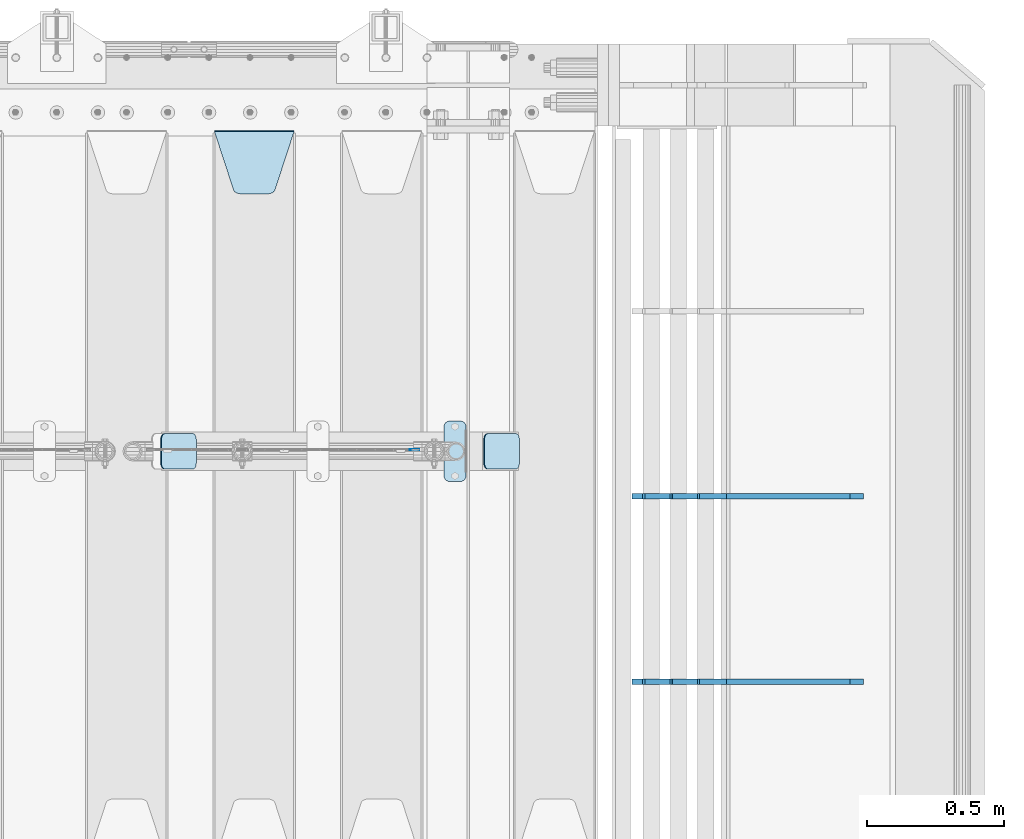
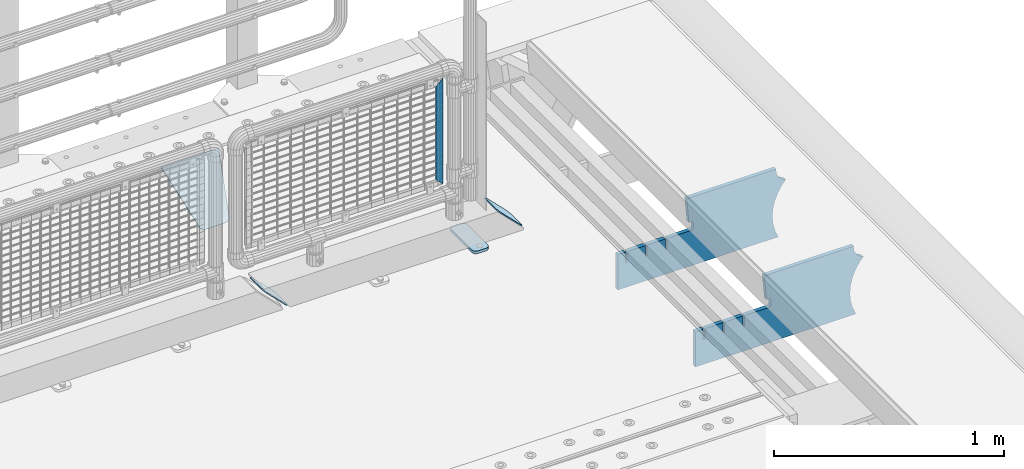
# One storey, part 192 of 208: 7 plates.
"""IFC2X3 building model written with IfcOpenShell, lengths in millimetres."""

import ifcopenshell
import ifcopenshell.guid

model = None  # the IFC model being written
_history = None  # IfcOwnerHistory: only IFC2X3 demands one
_inside = {}  # id of a spatial element -> (the spatial element, [elements in it])
_under = {}  # id of a project, library or spatial element -> (it, [spatial elements below it])
_declared = {}  # id of a project -> (the project, [libraries it declares])
_typed = {}  # id of a type object -> (the type object, [elements of that type])
_made_of = {}  # id of a material, layer set ... -> (it, [elements and type objects made of it])


def new_model(schema):
    """Start an empty IFC model of exactly this schema.

    Asked for "IFC4X3", IfcOpenShell would pick the latest addendum, in which some entities
    have other attributes; the version numbers below select the first issue.
    IFC2X3 requires an IfcOwnerHistory on every rooted entity: one is made here for all.
    """
    global model, _history
    if schema == "IFC4X3":
        model = ifcopenshell.file(schema_version=(4, 3, 0, 0))
    else:
        model = ifcopenshell.file(schema=schema)
    _inside.clear()
    _under.clear()
    _declared.clear()
    _typed.clear()
    _made_of.clear()
    _history = None
    if model.schema == "IFC2X3":
        org = make("IfcOrganization", Name="unknown")
        user = make(
            "IfcPersonAndOrganization",
            ThePerson=make("IfcPerson", FamilyName="unknown"),
            TheOrganization=org,
        )
        app = make(
            "IfcApplication",
            ApplicationDeveloper=org,
            Version="unknown",
            ApplicationFullName="unknown",
            ApplicationIdentifier="unknown",
        )
        _history = make(
            "IfcOwnerHistory",
            OwningUser=user,
            OwningApplication=app,
            ChangeAction="ADDED",
            CreationDate=0,
        )
    return model


def make(cls, **values):
    """One entity of the class cls with the attributes given. An attribute that is None is left unset."""
    return model.create_entity(
        cls, **{name: value for name, value in values.items() if value is not None}
    )


def rooted(cls, **values):
    """An entity with a GlobalId (a new one), such as an element, a storey or a relation."""
    return make(cls, GlobalId=ifcopenshell.guid.new(), OwnerHistory=_history, **values)


def si_unit(unit_type, name, prefix=None):
    """IfcSIUnit, for example si_unit("LENGTHUNIT", "METRE", prefix="MILLI")."""
    return make("IfcSIUnit", UnitType=unit_type, Prefix=prefix, Name=name)


def assignment(units):
    """IfcUnitAssignment: the units of a project."""
    return None if units is None else make("IfcUnitAssignment", Units=units)


def point(xyz):
    """IfcCartesianPoint."""
    return None if xyz is None else make("IfcCartesianPoint", Coordinates=xyz)


def direction(xyz):
    """IfcDirection."""
    return None if xyz is None else make("IfcDirection", DirectionRatios=xyz)


def frame(location, z_axis=None, x_axis=None):
    """IfcAxis2Placement3D, a coordinate frame: its origin and axes. An axis left out is left unset."""
    return make(
        "IfcAxis2Placement3D",
        Location=point(location),
        Axis=direction(z_axis),
        RefDirection=direction(x_axis),
    )


def origin_with_axes():
    """The frame at (0, 0, 0) with the z axis (0, 0, 1) and the x axis (1, 0, 0) written out."""
    return frame((0.0, 0.0, 0.0), z_axis=(0.0, 0.0, 1.0), x_axis=(1.0, 0.0, 0.0))


def place(relative_to, where):
    """IfcLocalPlacement: puts the frame where relative to a parent placement (None: the world)."""
    return make(
        "IfcLocalPlacement", PlacementRelTo=relative_to, RelativePlacement=where
    )


def context(
    kind, dimensions, precision=None, world=None, true_north=None, identifier=None
):
    """IfcGeometricRepresentationContext, for example the 3D "Model" context."""
    return make(
        "IfcGeometricRepresentationContext",
        ContextIdentifier=identifier,
        ContextType=kind,
        CoordinateSpaceDimension=dimensions,
        Precision=precision,
        WorldCoordinateSystem=world,
        TrueNorth=true_north,
    )


def subcontext(parent, identifier, kind, view, scale=None):
    """IfcGeometricRepresentationSubContext, for example "Body" below "Model"."""
    return make(
        "IfcGeometricRepresentationSubContext",
        ContextIdentifier=identifier,
        ContextType=kind,
        ParentContext=parent,
        TargetScale=scale,
        TargetView=view,
    )


def project(units=None, contexts=None):
    """IfcProject with its units and contexts."""
    return rooted(
        "IfcProject",
        Name="project",
        RepresentationContexts=contexts,
        UnitsInContext=assignment(units),
    )


def spatial(cls, under=None, at=None, **own):
    """A site, building, storey or space (cls), placed at a placement, below another one or the project."""
    s = rooted(cls, ObjectPlacement=at, **own)
    if under is not None:
        _under.setdefault(under.id(), (under, []))[1].append(s)
    return s


def faces_of(points, faces, orient=None, outer=None):
    """IfcFace entities. A face is a list of loops; a loop is a list of indices into points, from 0.

    orient and outer hold one flag for each loop. By default every Orientation is true, the
    first loop of a face is its IfcFaceOuterBound and the others are IfcFaceBound.
    """
    made = []
    for i, loops in enumerate(faces):
        bounds = []
        for j, loop in enumerate(loops):
            is_outer = j == 0 if outer is None else outer[i][j]
            bounds.append(
                make(
                    "IfcFaceOuterBound" if is_outer else "IfcFaceBound",
                    Bound=make("IfcPolyLoop", Polygon=[points[k] for k in loop]),
                    Orientation=True if orient is None else orient[i][j],
                )
            )
        made.append(make("IfcFace", Bounds=bounds))
    return made


def faceted_brep(points, faces, orient=None, outer=None, voids=None):
    """IfcFacetedBrep: a solid bounded by flat faces; with voids (closed shells), ...WithVoids."""
    shared = [point(p) for p in points]
    hull = make("IfcClosedShell", CfsFaces=faces_of(shared, faces, orient, outer))
    if voids is None:
        return make("IfcFacetedBrep", Outer=hull)
    return make(
        "IfcFacetedBrepWithVoids",
        Outer=hull,
        Voids=[
            make(cls, CfsFaces=faces_of(shared, fs, o, b)) for cls, fs, o, b in voids
        ],
    )


def shape(context_of_items, identifier, shape_type, items):
    """IfcShapeRepresentation: the items that make up one representation, for example the "Body"."""
    return make(
        "IfcShapeRepresentation",
        ContextOfItems=context_of_items,
        RepresentationIdentifier=identifier,
        RepresentationType=shape_type,
        Items=items,
    )


def material(Name=None, Category=None):
    """IfcMaterial."""
    return make("IfcMaterial", Name=Name, Category=Category)


def made_of(thing, what):
    """Note that an element or type object is made of a material, layer set ...; save() writes the relation."""
    if what is not None:
        _made_of.setdefault(what.id(), (what, []))[1].append(thing)
    return thing


def type_object(cls, material=None, **own):
    """A type object (cls), such as IfcWallType, which elements share."""
    return made_of(rooted(cls, **own), material)


def element(
    cls,
    number,
    at=None,
    inside=None,
    cuts=None,
    type_object=None,
    material=None,
    context=None,
    identifier="Body",
    shape_type=None,
    held_by="IfcProductDefinitionShape",
    body=None,
    shapes=None,
    **own,
):
    """One element of the class cls, such as IfcWall. Its Tag is "e" and its number.

    at: its placement. inside: the storey or other place that contains it. cuts: it is an
    opening in that element (IfcRelVoidsElement). A single representation is given by context,
    identifier, shape_type and body (its items); several are given by shapes. held_by: the class
    of the entity that holds the representations. save() writes the other relations.
    """
    e = rooted(cls, Tag="e%d" % number, ObjectPlacement=at, **own)
    if body is not None:
        shapes = [shape(context, identifier, shape_type, body)]
    if shapes is not None:
        e.Representation = make(held_by, Representations=shapes)
    if inside is not None:
        _inside.setdefault(inside.id(), (inside, []))[1].append(e)
    if cuts is not None:
        rooted(
            "IfcRelVoidsElement", RelatingBuildingElement=cuts, RelatedOpeningElement=e
        )
    if type_object is not None:
        _typed.setdefault(type_object.id(), (type_object, []))[1].append(e)
    return made_of(e, material)


def aggregate(whole, parts):
    """IfcRelAggregates: a whole, such as a stair, and the parts it consists of."""
    return rooted("IfcRelAggregates", RelatingObject=whole, RelatedObjects=parts)


def save(model, path):
    """Write the relations noted so far, then the file.

    IfcRelAggregates (storeys below a building ...), IfcRelContainedInSpatialStructure (elements
    in a storey), IfcRelDefinesByType, IfcRelAssociatesMaterial and IfcRelDeclares: one each for
    every whole, place, type object, material and project.
    """
    for whole, parts in _under.values():
        aggregate(whole, parts)
    for where, things in _inside.values():
        rooted(
            "IfcRelContainedInSpatialStructure",
            RelatedElements=things,
            RelatingStructure=where,
        )
    for kind, things in _typed.values():
        rooted("IfcRelDefinesByType", RelatedObjects=things, RelatingType=kind)
    for what, things in _made_of.values():
        rooted("IfcRelAssociatesMaterial", RelatedObjects=things, RelatingMaterial=what)
    for by, libraries in _declared.values():
        rooted("IfcRelDeclares", RelatingContext=by, RelatedDefinitions=libraries)
    model.write(path)


model = new_model("IFC2X3")

# Units and contexts
model_context = context("Model", 3, precision=1e-05, world=origin_with_axes())
body_context = subcontext(model_context, "Body", "Model", "MODEL_VIEW")
ifc_project = project(units=[si_unit("LENGTHUNIT", "METRE", prefix="MILLI"), si_unit("AREAUNIT", "SQUARE_METRE"), si_unit("VOLUMEUNIT", "CUBIC_METRE"), si_unit("MASSUNIT", "GRAM", prefix="KILO"), si_unit("TIMEUNIT", "SECOND"), si_unit("PLANEANGLEUNIT", "RADIAN"), si_unit("SOLIDANGLEUNIT", "STERADIAN"), si_unit("THERMODYNAMICTEMPERATUREUNIT", "DEGREE_CELSIUS"), si_unit("LUMINOUSINTENSITYUNIT", "LUMEN")], contexts=[model_context])

# Site, building, storey
site_placement = place(None, origin_with_axes())
site = spatial("IfcSite", under=ifc_project, at=site_placement, CompositionType="ELEMENT")
building_placement = place(site_placement, origin_with_axes())
building = spatial("IfcBuilding", under=site, at=building_placement, Name="Standard", CompositionType="ELEMENT")
storey_placement = place(building_placement, origin_with_axes())
storey = spatial("IfcBuildingStorey", under=building, at=storey_placement, Name="Undefined", CompositionType="ELEMENT", Elevation=0.0)

# Plates
ifc_material_1 = material(Name="STEEL/S355J2")
plate_type_1 = type_object("IfcPlateType", PredefinedType="NOTDEFINED")
plate_1_placement = place(storey_placement, frame((-26193.0, 4774.5, 21.0199999999977), z_axis=(1.0, 0.0, 0.0), x_axis=(0.0, -1.0, 0.0)))
element("IfcPlate", 1, at=plate_1_placement, inside=storey, type_object=plate_type_1, material=ifc_material_1, context=body_context, shape_type="Brep", body=[
    faceted_brep([(0.0, -7.0, 20.0), (0.0, -7.0, 60.0), (0.0, 7.0, 60.0), (0.0, 7.0, 20.0), (0.384294391935327, -7.0, 63.9018064403208), (0.384294391935327, 7.0, 63.9018064403208), (1.52240934977453, -7.0, 67.6536686473009), (1.52240934977453, 7.0, 67.6536686473009), (3.37060775394912, -7.0, 71.1114046603907), (3.37060775394912, 7.0, 71.1114046603907), (5.85786437626939, -7.0, 74.1421356237297), (5.85786437626939, 7.0, 74.1421356237297), (8.8885953396084, -7.0, 76.62939224605), (8.8885953396084, 7.0, 76.62939224605), (12.3463313526981, -7.0, 78.4775906502255), (12.3463313526981, 7.0, 78.4775906502255), (16.0981935596774, -7.0, 79.6157056080629), (16.0981935596774, 7.0, 79.6157056080629), (20.0, -7.0, 80.0), (20.0, 7.0, 80.0), (200.0, -7.0, 80.0), (200.0, 7.0, 80.0), (203.901806440323, -7.0, 79.6157056080629), (203.901806440323, 7.0, 79.6157056080629), (207.653668647302, -7.0, 78.4775906502255), (207.653668647302, 7.0, 78.4775906502255), (211.111404660393, -7.0, 76.62939224605), (211.111404660393, 7.0, 76.62939224605), (214.142135623731, -7.0, 74.1421356237297), (214.142135623731, 7.0, 74.1421356237297), (216.629392246051, -7.0, 71.1114046603907), (216.629392246051, 7.0, 71.1114046603907), (218.477590650225, -7.0, 67.6536686473009), (218.477590650225, 7.0, 67.6536686473009), (219.615705608065, -7.0, 63.9018064403208), (219.615705608065, 7.0, 63.9018064403208), (220.0, -7.0, 60.0), (220.0, 7.0, 60.0), (220.0, -7.0, 20.0), (220.0, 7.0, 20.0), (219.615705608065, -7.0, 16.0981935596792), (219.615705608065, 7.0, 16.0981935596792), (218.477590650225, -7.0, 12.3463313526991), (218.477590650225, 7.0, 12.3463313526991), (216.629392246051, -7.0, 8.88859533960931), (216.629392246051, 7.0, 8.88859533960931), (214.142135623731, -7.0, 5.8578643762703), (214.142135623731, 7.0, 5.8578643762703), (211.111404660393, -7.0, 3.37060775395003), (211.111404660393, 7.0, 3.37060775395003), (207.653668647302, -7.0, 1.52240934977453), (207.653668647302, 7.0, 1.52240934977453), (203.901806440323, -7.0, 0.384294391937146), (203.901806440323, 7.0, 0.384294391937146), (200.0, -7.0, 0.0), (200.0, 7.0, 0.0), (20.0, -7.0, 0.0), (20.0, 7.0, 0.0), (16.0981935596774, -7.0, 0.384294391937146), (16.0981935596774, 7.0, 0.384294391937146), (12.3463313526981, -7.0, 1.52240934977453), (12.3463313526981, 7.0, 1.52240934977453), (8.8885953396084, -7.0, 3.37060775395003), (8.8885953396084, 7.0, 3.37060775395003), (5.85786437626939, -7.0, 5.8578643762703), (5.85786437626939, 7.0, 5.8578643762703), (3.37060775394912, -7.0, 8.88859533960931), (3.37060775394912, 7.0, 8.88859533960931), (1.52240934977453, -7.0, 12.3463313526991), (1.52240934977453, 7.0, 12.3463313526991), (0.384294391935327, -7.0, 16.0981935596792), (0.384294391935327, 7.0, 16.0981935596792)], [[[0, 1, 2, 3]], [[1, 4, 5, 2]], [[4, 6, 7, 5]], [[6, 8, 9, 7]], [[8, 10, 11, 9]], [[10, 12, 13, 11]], [[12, 14, 15, 13]], [[14, 16, 17, 15]], [[16, 18, 19, 17]], [[18, 20, 21, 19]], [[20, 22, 23, 21]], [[22, 24, 25, 23]], [[24, 26, 27, 25]], [[26, 28, 29, 27]], [[28, 30, 31, 29]], [[30, 32, 33, 31]], [[32, 34, 35, 33]], [[34, 36, 37, 35]], [[36, 38, 39, 37]], [[38, 40, 41, 39]], [[40, 42, 43, 41]], [[42, 44, 45, 43]], [[44, 46, 47, 45]], [[46, 48, 49, 47]], [[48, 50, 51, 49]], [[50, 52, 53, 51]], [[52, 54, 55, 53]], [[54, 56, 57, 55]], [[56, 58, 59, 57]], [[58, 60, 61, 59]], [[60, 62, 63, 61]], [[62, 64, 65, 63]], [[64, 66, 67, 65]], [[66, 68, 69, 67]], [[68, 70, 71, 69]], [[70, 0, 3, 71]], [[5, 7, 9, 11, 13, 15, 17, 19, 21, 23, 25, 27, 29, 31, 33, 35, 37, 39, 41, 43, 45, 47, 49, 51, 53, 55, 57, 59, 61, 63, 65, 67, 69, 71, 3, 2]], [[70, 68, 66, 64, 62, 60, 58, 56, 54, 52, 50, 48, 46, 44, 42, 40, 38, 36, 34, 32, 30, 28, 26, 24, 22, 20, 18, 16, 14, 12, 10, 8, 6, 4, 1, 0]]]),
])
ifc_material_2 = material(Name="STEEL/S355N")
plate_type_2 = type_object("IfcPlateType", PredefinedType="NOTDEFINED")
plate_2_placement = place(storey_placement, frame((-27030.0, 5831.76776695596, -1.76776695296758), z_axis=(0.0, -0.707106781186548, -0.707106781186547), x_axis=(1.0, 0.0, 0.0)))
element("IfcPlate", 2, at=plate_2_placement, inside=storey, type_object=plate_type_2, material=ifc_material_2, context=body_context, shape_type="Brep", body=[
    faceted_brep([(0.0, -2.5, 0.0), (69.345504679477, -2.5, 300.17173142483), (69.345504679477, 2.5, 300.17173142483), (0.0, 2.5, 0.0), (70.9274061199576, -2.5, 304.897442415399), (70.9274061199576, 2.5, 304.8974424154), (73.3818627772307, -2.5, 309.234538108527), (73.3818627772307, 2.5, 309.234538108527), (76.6187032999551, -2.5, 313.023683126103), (76.6187032999551, 2.5, 313.023683126103), (80.5190132704993, -2.5, 316.125672595371), (80.5190132704993, 2.5, 316.125672595371), (84.9395038596849, -2.5, 318.426546230476), (84.9395038596849, 2.50000000000091, 318.426546230476), (89.7177759439219, -2.5, 319.841774983275), (89.7177759439219, 2.50000000000091, 319.841774983275), (94.678286292652, -2.49999999999909, 320.319366455078), (94.678286292652, 2.5, 320.319366455078), (195.321713707348, -2.49999999999909, 320.319366455078), (195.321713707348, 2.5, 320.319366455078), (200.282224056078, -2.5, 319.841774983275), (200.282224056078, 2.5, 319.841774983274), (205.060496140315, -2.5, 318.426546230475), (205.060496140315, 2.5, 318.426546230475), (209.480986729501, -2.5, 316.125672595371), (209.480986729501, 2.50000000000091, 316.125672595371), (213.381296700045, -2.5, 313.023683126102), (213.381296700045, 2.5, 313.023683126102), (216.618137222769, -2.5, 309.234538108526), (216.618137222769, 2.5, 309.234538108527), (219.072593880042, -2.5, 304.897442415399), (219.072593880042, 2.5, 304.897442415399), (220.654495320523, -2.5, 300.17173142483), (220.654495320523, 2.5, 300.17173142483), (290.0, -2.5, 0.0), (290.0, 2.5, 0.0)], [[[0, 1, 2, 3]], [[1, 4, 5, 2]], [[4, 6, 7, 5]], [[6, 8, 9, 7]], [[8, 10, 11, 9]], [[10, 12, 13, 11]], [[12, 14, 15, 13]], [[14, 16, 17, 15]], [[16, 18, 19, 17]], [[18, 20, 21, 19]], [[20, 22, 23, 21]], [[22, 24, 25, 23]], [[24, 26, 27, 25]], [[26, 28, 29, 27]], [[28, 30, 31, 29]], [[30, 32, 33, 31]], [[32, 34, 35, 33]], [[34, 0, 3, 35]], [[5, 7, 9, 11, 13, 15, 17, 19, 21, 23, 25, 27, 29, 31, 33, 35, 3, 2]], [[34, 32, 30, 28, 26, 24, 22, 20, 18, 16, 14, 12, 10, 8, 6, 4, 1, 0]]]),
])
ifc_material_3 = material(Name="Misc_Undefined")
plate_type_3 = type_object("IfcPlateType", PredefinedType="NOTDEFINED")
plate_3_placement = place(storey_placement, frame((-26283.5000000138, 4670.49977880131, 914.461469028508), z_axis=(0.706514791587334, 1.29999998458982e-08, -0.707698275586641), x_axis=(-0.70769827558663, 0.0, -0.706514791587346)))
element("IfcPlate", 3, at=plate_3_placement, inside=storey, type_object=plate_type_3, material=ifc_material_3, context=body_context, shape_type="Brep", body=[
    faceted_brep([(0.0, -1.49999999999909, 3.63797880709171e-12), (397.726470947258, -1.5, 398.392700195313), (397.726470947258, 1.5, 398.392700195313), (0.0, 1.50000000000182, 3.63797880709171e-12), (397.767883300774, -1.5, 348.895263671871), (397.767883300774, 1.5, 348.895263671875), (49.4561042785645, -1.5, -5.45696821063757e-11), (49.4561042785645, 1.5, -5.0931703299284e-11)], [[[0, 1, 2, 3]], [[1, 4, 5, 2]], [[4, 6, 7, 5]], [[6, 0, 3, 7]], [[5, 7, 3, 2]], [[6, 4, 1, 0]]]),
])
plate_type_4 = type_object("IfcPlateType", PredefinedType="NOTDEFINED")
plate_4_placement = place(storey_placement, frame((-26046.807581521, 4729.5, 166.254400376567), z_axis=(0.707410512925777, 0.0, -0.706802918925841), x_axis=(0.0, -1.0, 0.0)))
element("IfcPlate", 4, at=plate_4_placement, inside=storey, type_object=plate_type_4, material=ifc_material_1, context=body_context, shape_type="Brep", body=[
    faceted_brep([(0.0, -2.49999999999636, 20.0000000000036), (0.0, -2.49999999999636, 158.92665100098), (0.0, 2.5, 158.92665100098), (0.0, 2.50000000000364, 20.0000000000036), (0.384294391935327, -2.5, 162.828457441301), (0.384294391935327, 2.50000000000364, 162.828457441305), (1.52240934977453, -2.49999999999636, 166.580319648281), (1.52240934977453, 2.50000000000364, 166.580319648281), (3.37060775394912, -2.49999999999636, 170.038055661371), (3.37060775394912, 2.50000000000364, 170.038055661375), (5.85786437626939, -2.49999999999636, 173.06878662471), (5.85786437626939, 2.50000000000364, 173.06878662471), (8.8885953396084, -2.5, 175.55604324703), (8.8885953396084, 2.5, 175.55604324703), (12.3463313526981, -2.49999999999636, 177.404241651206), (12.3463313526981, 2.50000000000364, 177.404241651206), (16.0981935596774, -2.5, 178.542356609047), (16.0981935596774, 2.50000000000364, 178.542356609043), (20.0, -2.49999999999272, 178.92665100098), (20.0, 2.50000000000364, 178.92665100098), (110.0, -2.49999999999272, 178.92665100098), (110.0, 2.50000000000364, 178.92665100098), (113.901806440323, -2.5, 178.542356609047), (113.901806440323, 2.50000000000364, 178.542356609043), (117.653668647302, -2.49999999999636, 177.404241651206), (117.653668647302, 2.50000000000364, 177.404241651206), (121.111404660392, -2.5, 175.55604324703), (121.111404660392, 2.5, 175.55604324703), (124.142135623731, -2.49999999999636, 173.06878662471), (124.142135623731, 2.50000000000364, 173.06878662471), (126.629392246051, -2.49999999999636, 170.038055661371), (126.629392246051, 2.50000000000364, 170.038055661375), (128.477590650225, -2.49999999999636, 166.580319648281), (128.477590650225, 2.50000000000364, 166.580319648281), (129.615705608065, -2.5, 162.828457441301), (129.615705608065, 2.50000000000364, 162.828457441305), (130.0, -2.49999999999636, 158.92665100098), (130.0, 2.5, 158.92665100098), (130.0, -2.49999999999636, 20.0000000000036), (130.0, 2.50000000000364, 20.0000000000036), (129.615705608065, -2.49999999999636, 16.0981935596792), (129.615705608065, 2.50000000000364, 16.0981935596792), (128.477590650225, -2.49999999999636, 12.3463313526991), (128.477590650225, 2.50000000000364, 12.3463313526991), (126.629392246051, -2.49999999999636, 8.88859533961295), (126.629392246051, 2.5, 8.88859533960931), (124.142135623731, -2.49999999999636, 5.85786437627394), (124.142135623731, 2.5, 5.85786437627394), (121.111404660392, -2.49999999999636, 3.37060775395003), (121.111404660392, 2.50000000000364, 3.37060775395003), (117.653668647302, -2.5, 1.52240934977453), (117.653668647302, 2.50000000000364, 1.52240934977817), (113.901806440323, -2.49999999999636, 0.384294391937146), (113.901806440323, 2.50000000000364, 0.384294391937146), (110.0, -2.5, 7.27595761418343e-12), (110.0, 2.50000000000364, 3.63797880709171e-12), (20.0, -2.5, 7.27595761418343e-12), (20.0, 2.50000000000364, 3.63797880709171e-12), (16.0981935596774, -2.49999999999636, 0.384294391937146), (16.0981935596774, 2.50000000000364, 0.384294391937146), (12.3463313526981, -2.5, 1.52240934977453), (12.3463313526981, 2.50000000000364, 1.52240934977817), (8.8885953396084, -2.49999999999636, 3.37060775395003), (8.8885953396084, 2.50000000000364, 3.37060775395003), (5.85786437626939, -2.49999999999636, 5.85786437627394), (5.85786437626939, 2.5, 5.85786437627394), (3.37060775394912, -2.49999999999636, 8.88859533961295), (3.37060775394912, 2.5, 8.88859533960931), (1.52240934977453, -2.49999999999636, 12.3463313526991), (1.52240934977453, 2.50000000000364, 12.3463313526991), (0.384294391935327, -2.49999999999636, 16.0981935596792), (0.384294391935327, 2.50000000000364, 16.0981935596792)], [[[0, 1, 2, 3]], [[1, 4, 5, 2]], [[4, 6, 7, 5]], [[6, 8, 9, 7]], [[8, 10, 11, 9]], [[10, 12, 13, 11]], [[12, 14, 15, 13]], [[14, 16, 17, 15]], [[16, 18, 19, 17]], [[18, 20, 21, 19]], [[20, 22, 23, 21]], [[22, 24, 25, 23]], [[24, 26, 27, 25]], [[26, 28, 29, 27]], [[28, 30, 31, 29]], [[30, 32, 33, 31]], [[32, 34, 35, 33]], [[34, 36, 37, 35]], [[36, 38, 39, 37]], [[38, 40, 41, 39]], [[40, 42, 43, 41]], [[42, 44, 45, 43]], [[44, 46, 47, 45]], [[46, 48, 49, 47]], [[48, 50, 51, 49]], [[50, 52, 53, 51]], [[52, 54, 55, 53]], [[54, 56, 57, 55]], [[56, 58, 59, 57]], [[58, 60, 61, 59]], [[60, 62, 63, 61]], [[62, 64, 65, 63]], [[64, 66, 67, 65]], [[66, 68, 69, 67]], [[68, 70, 71, 69]], [[70, 0, 3, 71]], [[5, 7, 9, 11, 13, 15, 17, 19, 21, 23, 25, 27, 29, 31, 33, 35, 37, 39, 41, 43, 45, 47, 49, 51, 53, 55, 57, 59, 61, 63, 65, 67, 69, 71, 3, 2]], [[70, 68, 66, 64, 62, 60, 58, 56, 54, 52, 50, 48, 46, 44, 42, 40, 38, 36, 34, 32, 30, 28, 26, 24, 22, 20, 18, 16, 14, 12, 10, 8, 6, 4, 1, 0]]]),
])
plate_5_placement = place(storey_placement, frame((-27224.8785374619, 4729.5, 156.251473717902), z_axis=(0.707410512925777, 0.0, -0.706802918925841), x_axis=(0.0, -1.0, 0.0)))
element("IfcPlate", 5, at=plate_5_placement, inside=storey, type_object=plate_type_4, material=ifc_material_1, context=body_context, shape_type="Brep", body=[
    faceted_brep([(0.0, -2.49999999999636, 20.0000000000036), (0.0, -2.49999999999636, 158.92665100098), (0.0, 2.5, 158.92665100098), (0.0, 2.50000000000364, 20.0000000000036), (0.384294391935327, -2.5, 162.828457441301), (0.384294391935327, 2.50000000000364, 162.828457441305), (1.52240934977453, -2.49999999999636, 166.580319648281), (1.52240934977453, 2.50000000000364, 166.580319648281), (3.37060775394912, -2.49999999999636, 170.038055661371), (3.37060775394912, 2.50000000000364, 170.038055661375), (5.85786437626939, -2.49999999999636, 173.06878662471), (5.85786437626939, 2.50000000000364, 173.06878662471), (8.8885953396084, -2.5, 175.55604324703), (8.8885953396084, 2.5, 175.55604324703), (12.3463313526981, -2.49999999999636, 177.404241651206), (12.3463313526981, 2.50000000000364, 177.404241651206), (16.0981935596774, -2.5, 178.542356609047), (16.0981935596774, 2.50000000000364, 178.542356609043), (20.0, -2.49999999999272, 178.92665100098), (20.0, 2.50000000000364, 178.92665100098), (110.0, -2.49999999999272, 178.92665100098), (110.0, 2.50000000000364, 178.92665100098), (113.901806440323, -2.5, 178.542356609047), (113.901806440323, 2.50000000000364, 178.542356609043), (117.653668647302, -2.49999999999636, 177.404241651206), (117.653668647302, 2.50000000000364, 177.404241651206), (121.111404660392, -2.5, 175.55604324703), (121.111404660392, 2.5, 175.55604324703), (124.142135623731, -2.49999999999636, 173.06878662471), (124.142135623731, 2.50000000000364, 173.06878662471), (126.629392246051, -2.49999999999636, 170.038055661371), (126.629392246051, 2.50000000000364, 170.038055661375), (128.477590650225, -2.49999999999636, 166.580319648281), (128.477590650225, 2.50000000000364, 166.580319648281), (129.615705608065, -2.5, 162.828457441301), (129.615705608065, 2.50000000000364, 162.828457441305), (130.0, -2.49999999999636, 158.92665100098), (130.0, 2.5, 158.92665100098), (130.0, -2.49999999999636, 20.0000000000036), (130.0, 2.50000000000364, 20.0000000000036), (129.615705608065, -2.49999999999636, 16.0981935596792), (129.615705608065, 2.50000000000364, 16.0981935596792), (128.477590650225, -2.49999999999636, 12.3463313526991), (128.477590650225, 2.50000000000364, 12.3463313526991), (126.629392246051, -2.49999999999636, 8.88859533961295), (126.629392246051, 2.5, 8.88859533960931), (124.142135623731, -2.49999999999636, 5.85786437627394), (124.142135623731, 2.5, 5.85786437627394), (121.111404660392, -2.49999999999636, 3.37060775395003), (121.111404660392, 2.50000000000364, 3.37060775395003), (117.653668647302, -2.5, 1.52240934977453), (117.653668647302, 2.50000000000364, 1.52240934977817), (113.901806440323, -2.49999999999636, 0.384294391937146), (113.901806440323, 2.50000000000364, 0.384294391937146), (110.0, -2.5, 7.27595761418343e-12), (110.0, 2.50000000000364, 3.63797880709171e-12), (20.0, -2.5, 7.27595761418343e-12), (20.0, 2.50000000000364, 3.63797880709171e-12), (16.0981935596774, -2.49999999999636, 0.384294391937146), (16.0981935596774, 2.50000000000364, 0.384294391937146), (12.3463313526981, -2.5, 1.52240934977453), (12.3463313526981, 2.50000000000364, 1.52240934977817), (8.8885953396084, -2.49999999999636, 3.37060775395003), (8.8885953396084, 2.50000000000364, 3.37060775395003), (5.85786437626939, -2.49999999999636, 5.85786437627394), (5.85786437626939, 2.5, 5.85786437627394), (3.37060775394912, -2.49999999999636, 8.88859533961295), (3.37060775394912, 2.5, 8.88859533960931), (1.52240934977453, -2.49999999999636, 12.3463313526991), (1.52240934977453, 2.50000000000364, 12.3463313526991), (0.384294391935327, -2.49999999999636, 16.0981935596792), (0.384294391935327, 2.50000000000364, 16.0981935596792)], [[[0, 1, 2, 3]], [[1, 4, 5, 2]], [[4, 6, 7, 5]], [[6, 8, 9, 7]], [[8, 10, 11, 9]], [[10, 12, 13, 11]], [[12, 14, 15, 13]], [[14, 16, 17, 15]], [[16, 18, 19, 17]], [[18, 20, 21, 19]], [[20, 22, 23, 21]], [[22, 24, 25, 23]], [[24, 26, 27, 25]], [[26, 28, 29, 27]], [[28, 30, 31, 29]], [[30, 32, 33, 31]], [[32, 34, 35, 33]], [[34, 36, 37, 35]], [[36, 38, 39, 37]], [[38, 40, 41, 39]], [[40, 42, 43, 41]], [[42, 44, 45, 43]], [[44, 46, 47, 45]], [[46, 48, 49, 47]], [[48, 50, 51, 49]], [[50, 52, 53, 51]], [[52, 54, 55, 53]], [[54, 56, 57, 55]], [[56, 58, 59, 57]], [[58, 60, 61, 59]], [[60, 62, 63, 61]], [[62, 64, 65, 63]], [[64, 66, 67, 65]], [[66, 68, 69, 67]], [[68, 70, 71, 69]], [[70, 0, 3, 71]], [[5, 7, 9, 11, 13, 15, 17, 19, 21, 23, 25, 27, 29, 31, 33, 35, 37, 39, 41, 43, 45, 47, 49, 51, 53, 55, 57, 59, 61, 63, 65, 67, 69, 71, 3, 2]], [[70, 68, 66, 64, 62, 60, 58, 56, 54, 52, 50, 48, 46, 44, 42, 40, 38, 36, 34, 32, 30, 28, 26, 24, 22, 20, 18, 16, 14, 12, 10, 8, 6, 4, 1, 0]]]),
])
plate_type_5 = type_object("IfcPlateType", PredefinedType="NOTDEFINED")
plate_6_placement = place(storey_placement, frame((-24667.0817660324, 3824.99928283691, -374.002067436516), z_axis=(0.0, 0.0, 1.0), x_axis=(-1.0, 0.0, 0.0)))
element("IfcPlate", 6, at=plate_6_placement, inside=storey, type_object=plate_type_5, material=ifc_material_2, context=body_context, shape_type="Brep", body=[
    faceted_brep([(801.919404066546, -10.0, 188.0), (801.919404066546, 10.0, 188.0), (801.919404066546, 10.0000000000001, 132.002067436952), (801.919404066546, -10.0, 132.002067436952), (793.919404066546, 10.0000000000001, 132.002067436952), (793.919404066546, -10.0, 132.002067436952), (793.919404066546, 10.0000000000001, 180.002067436952), (793.919404066546, -10.0, 180.002067436952), (793.527856196906, 10.0000000000001, 182.474203391951), (793.527856196906, -10.0, 182.474203391951), (792.391540021545, 10.0000000000001, 184.704349455291), (792.391540021545, -10.0, 184.704349455291), (790.621686084887, 10.0000000000001, 186.474203391951), (790.621686084887, -10.0, 186.474203391951), (788.391540021545, 10.0000000000001, 187.610519567313), (788.391540021545, -10.0, 187.610519567313), (785.919404066546, -10.0, 188.002067436952), (785.919404066546, 10.0, 188.0), (841.0, -10.0, 188.0), (841.0, -10.0, 0.0), (841.0, 10.0, 0.0), (841.0, 10.0, 188.0), (33.3619566735979, -10.0, 0.0), (33.3619566735979, 10.0, 0.0), (36.2350612208174, -10.0, 4.68848050267007), (36.2350612208174, 10.0, 4.68848050267007), (51.4877592159428, -10.0, 41.5117508652783), (51.4877592159428, 10.0, 41.5117508652783), (60.792242588137, -10.0, 80.2677133162963), (60.792242588137, 10.0, 80.2677133162963), (63.9194040769726, -10.0, 120.002067436515), (63.9194040769726, 10.0, 120.002067436515), (60.792242588137, -10.0, 159.736421556734), (60.792242588137, 10.0, 159.736421556734), (51.4877592159428, -10.0, 198.492384007752), (51.4877592159428, 10.0, 198.492384007752), (36.2350612208174, -10.0, 235.31565437036), (36.2350612208174, 10.0, 235.31565437036), (15.4097206482074, -10.0, 269.299521518803), (15.4097206482074, 10.0, 269.299521518803), (-3.35474438098754, -10.0, 291.269887256574), (-3.35474438098754, 10.0, 291.269887256574), (-2.36881039375294, -10.0, 291.426043859339), (-2.36881039375294, 10.0, 291.426043859339), (17.1449676604716, -10.0, 301.368810393754), (17.1449676604716, 10.0, 301.368810393754), (32.6311896062471, -10.0, 316.855032339527), (32.6311896062471, 10.0, 316.855032339527), (42.573956140659, -10.0, 336.368810393754), (42.573956140659, 10.0, 336.368810393754), (46.0, -10.0, 358.0), (46.0, 10.0, 358.0), (45.0495205499174, -10.0, 364.001091067617), (45.0495205499174, 10.0, 364.001091067617), (495.040008544922, -10.0, 364.010009765625), (495.040008544922, 10.0, 364.010009765625), (483.600036621094, -10.0, 233.759994506836), (483.600036621094, 10.0, 233.759994506836), (472.0, -10.0, 233.759994506836), (472.0, 10.0, 233.759994506836), (468.909830056251, -10.0, 233.270559669787), (468.909830056251, 10.0, 233.270559669787), (466.122147477075, -10.0, 231.850164450585), (466.122147477075, 10.0, 231.850164450585), (463.909830056251, -10.0, 229.637847029761), (463.909830056251, 10.0, 229.637847029761), (462.489434837047, -10.0, 226.850164450585), (462.489434837047, 10.0, 226.850164450585), (462.0, -10.0, 223.759994506836), (462.0, 10.0, 223.759994506836), (462.0, -10.0, 198.0), (462.0, 10.0, 198.0), (462.489434837047, -10.0, 194.909830056251), (462.489434837047, 10.0, 194.909830056251), (463.909830056251, -10.0, 192.122147477075), (463.909830056251, 10.0, 192.122147477075), (466.122147477075, -10.0, 189.909830056251), (466.122147477075, 10.0, 189.909830056251), (468.909830056251, -10.0, 188.489434837048), (468.909830056251, 10.0, 188.489434837048), (472.0, -10.0, 188.0), (472.0, 10.0, 188.0), (585.919404066546, -10.0, 188.002067436952), (585.919404066546, 10.0, 188.0), (588.391540021545, -10.0, 187.610519567313), (588.391540021545, 10.0, 187.610519567313), (590.621686084887, -10.0, 186.474203391951), (590.621686084887, 10.0, 186.474203391951), (592.391540021545, -10.0, 184.704349455291), (592.391540021545, 10.0, 184.704349455291), (593.527856196906, -10.0, 182.474203391951), (593.527856196906, 10.0, 182.474203391951), (593.919404066546, -10.0, 180.002067436952), (593.919404066546, 10.0, 180.002067436952), (593.919404066546, -10.0, 132.002067436952), (593.919404066546, 10.0, 132.002067436952), (601.919404066546, -10.0, 132.002067436952), (601.919404066546, 10.0, 132.002067436952), (601.919404066546, -10.0, 188.0), (601.919404066546, 10.0, 188.0), (685.919404066546, -10.0, 188.002067436952), (685.919404066546, 10.0, 188.0), (688.391540021545, -10.0, 187.610519567313), (688.391540021545, 10.0, 187.610519567313), (690.621686084887, -10.0, 186.474203391951), (690.621686084887, 10.0, 186.474203391951), (692.391540021545, -10.0, 184.704349455291), (692.391540021545, 10.0, 184.704349455291), (693.527856196906, -10.0, 182.474203391951), (693.527856196906, 10.0, 182.474203391951), (693.919404066546, -10.0, 180.002067436952), (693.919404066546, 10.0, 180.002067436952), (693.919404066546, -10.0, 132.002067436952), (693.919404066546, 9.99999999999989, 132.002067436952), (701.919404066546, -10.0, 132.002067436952), (701.919404066546, 9.99999999999989, 132.002067436952), (701.919404066546, -10.0, 188.0), (701.919404066546, 10.0, 188.0)], [[[0, 1, 2, 3]], [[3, 2, 4, 5]], [[5, 4, 6, 7]], [[7, 6, 8, 9]], [[9, 8, 10, 11]], [[11, 10, 12, 13]], [[13, 12, 14, 15]], [[16, 15, 14, 17]], [[18, 19, 20, 21]], [[20, 19, 22, 23]], [[22, 24, 25, 23]], [[26, 27, 25, 24]], [[28, 29, 27, 26]], [[30, 31, 29, 28]], [[32, 33, 31, 30]], [[34, 35, 33, 32]], [[36, 37, 35, 34]], [[38, 39, 37, 36]], [[39, 38, 40, 41]], [[40, 42, 43, 41]], [[44, 45, 43, 42]], [[46, 47, 45, 44]], [[48, 49, 47, 46]], [[50, 51, 49, 48]], [[52, 53, 51, 50]], [[54, 55, 53, 52]], [[54, 56, 57, 55]], [[56, 58, 59, 57]], [[58, 60, 61, 59]], [[60, 62, 63, 61]], [[62, 64, 65, 63]], [[64, 66, 67, 65]], [[66, 68, 69, 67]], [[68, 70, 71, 69]], [[70, 72, 73, 71]], [[72, 74, 75, 73]], [[74, 76, 77, 75]], [[76, 78, 79, 77]], [[78, 80, 81, 79]], [[81, 80, 82, 83]], [[82, 84, 85, 83]], [[86, 87, 85, 84]], [[88, 89, 87, 86]], [[90, 91, 89, 88]], [[92, 93, 91, 90]], [[94, 95, 93, 92]], [[96, 97, 95, 94]], [[98, 99, 97, 96]], [[99, 98, 100, 101]], [[100, 102, 103, 101]], [[104, 105, 103, 102]], [[106, 107, 105, 104]], [[108, 109, 107, 106]], [[110, 111, 109, 108]], [[112, 113, 111, 110]], [[114, 115, 113, 112]], [[116, 117, 115, 114]], [[117, 116, 16, 17]], [[12, 10, 8, 6, 4, 2, 1, 21, 20, 23, 25, 27, 29, 31, 33, 35, 37, 39, 41, 43, 45, 47, 49, 51, 53, 55, 57, 59, 61, 63, 65, 67, 69, 71, 73, 75, 77, 79, 81, 83, 85, 87, 89, 91, 93, 95, 97, 99, 101, 103, 105, 107, 109, 111, 113, 115, 117, 17, 14]], [[18, 21, 1, 0]], [[116, 114, 112, 110, 108, 106, 104, 102, 100, 98, 96, 94, 92, 90, 88, 86, 84, 82, 80, 78, 76, 74, 72, 70, 68, 66, 64, 62, 60, 58, 56, 54, 52, 50, 48, 46, 44, 42, 40, 38, 36, 34, 32, 30, 28, 26, 24, 22, 19, 18, 0, 3, 5, 7, 9, 11, 13, 15, 16]]]),
])
plate_7_placement = place(storey_placement, frame((-24667.0817660324, 4499.99928283691, -374.002067436516), z_axis=(0.0, 0.0, 1.0), x_axis=(-1.0, 0.0, 0.0)))
element("IfcPlate", 7, at=plate_7_placement, inside=storey, type_object=plate_type_5, material=ifc_material_2, context=body_context, shape_type="Brep", body=[
    faceted_brep([(801.919404066546, -10.0, 188.0), (801.919404066546, 10.0, 188.0), (801.919404066546, 10.0000000000001, 132.002067436952), (801.919404066546, -10.0, 132.002067436952), (793.919404066546, 10.0000000000001, 132.002067436952), (793.919404066546, -10.0, 132.002067436952), (793.919404066546, 10.0000000000001, 180.002067436952), (793.919404066546, -10.0, 180.002067436952), (793.527856196906, 10.0000000000001, 182.474203391951), (793.527856196906, -10.0, 182.474203391951), (792.391540021545, 10.0000000000001, 184.704349455291), (792.391540021545, -10.0, 184.704349455291), (790.621686084887, 10.0000000000001, 186.474203391951), (790.621686084887, -10.0, 186.474203391951), (788.391540021545, 10.0000000000001, 187.610519567313), (788.391540021545, -10.0, 187.610519567313), (785.919404066546, -10.0, 188.002067436952), (785.919404066546, 10.0, 188.0), (841.0, -10.0, 188.0), (841.0, -10.0, 0.0), (841.0, 10.0, 0.0), (841.0, 10.0, 188.0), (33.3619566735979, -10.0, 0.0), (33.3619566735979, 10.0, 0.0), (36.2350612208174, -10.0, 4.68848050267007), (36.2350612208174, 10.0, 4.68848050267007), (51.4877592159428, -10.0, 41.5117508652783), (51.4877592159428, 10.0, 41.5117508652783), (60.792242588137, -10.0, 80.2677133162963), (60.792242588137, 10.0, 80.2677133162963), (63.9194040769726, -10.0, 120.002067436515), (63.9194040769726, 10.0, 120.002067436515), (60.792242588137, -10.0, 159.736421556734), (60.792242588137, 10.0, 159.736421556734), (51.4877592159428, -10.0, 198.492384007752), (51.4877592159428, 10.0, 198.492384007752), (36.2350612208174, -10.0, 235.31565437036), (36.2350612208174, 10.0, 235.31565437036), (15.4097206482074, -10.0, 269.299521518803), (15.4097206482074, 10.0, 269.299521518803), (-3.35474438098754, -10.0, 291.269887256574), (-3.35474438098754, 10.0, 291.269887256574), (-2.36881039375294, -10.0, 291.426043859339), (-2.36881039375294, 10.0, 291.426043859339), (17.1449676604716, -10.0, 301.368810393754), (17.1449676604716, 10.0, 301.368810393754), (32.6311896062471, -10.0, 316.855032339527), (32.6311896062471, 10.0, 316.855032339527), (42.573956140659, -10.0, 336.368810393754), (42.573956140659, 10.0, 336.368810393754), (46.0, -10.0, 358.0), (46.0, 10.0, 358.0), (45.0495205499174, -10.0, 364.001091067617), (45.0495205499174, 10.0, 364.001091067617), (495.040008544922, -10.0, 364.010009765625), (495.040008544922, 10.0, 364.010009765625), (483.600036621094, -10.0, 233.759994506836), (483.600036621094, 10.0, 233.759994506836), (472.0, -10.0, 233.759994506836), (472.0, 10.0, 233.759994506836), (468.909830056251, -10.0, 233.270559669787), (468.909830056251, 10.0, 233.270559669787), (466.122147477075, -10.0, 231.850164450585), (466.122147477075, 10.0, 231.850164450585), (463.909830056251, -10.0, 229.637847029761), (463.909830056251, 10.0, 229.637847029761), (462.489434837047, -10.0, 226.850164450585), (462.489434837047, 10.0, 226.850164450585), (462.0, -10.0, 223.759994506836), (462.0, 10.0, 223.759994506836), (462.0, -10.0, 198.0), (462.0, 10.0, 198.0), (462.489434837047, -10.0, 194.909830056251), (462.489434837047, 10.0, 194.909830056251), (463.909830056251, -10.0, 192.122147477075), (463.909830056251, 10.0, 192.122147477075), (466.122147477075, -10.0, 189.909830056251), (466.122147477075, 10.0, 189.909830056251), (468.909830056251, -10.0, 188.489434837048), (468.909830056251, 10.0, 188.489434837048), (472.0, -10.0, 188.0), (472.0, 10.0, 188.0), (585.919404066546, -10.0, 188.002067436952), (585.919404066546, 10.0, 188.0), (588.391540021545, -10.0, 187.610519567313), (588.391540021545, 10.0, 187.610519567313), (590.621686084887, -10.0, 186.474203391951), (590.621686084887, 10.0, 186.474203391951), (592.391540021545, -10.0, 184.704349455291), (592.391540021545, 10.0, 184.704349455291), (593.527856196906, -10.0, 182.474203391951), (593.527856196906, 10.0, 182.474203391951), (593.919404066546, -10.0, 180.002067436952), (593.919404066546, 10.0, 180.002067436952), (593.919404066546, -10.0, 132.002067436952), (593.919404066546, 10.0, 132.002067436952), (601.919404066546, -10.0, 132.002067436952), (601.919404066546, 10.0, 132.002067436952), (601.919404066546, -10.0, 188.0), (601.919404066546, 10.0, 188.0), (685.919404066546, -10.0, 188.002067436952), (685.919404066546, 10.0, 188.0), (688.391540021545, -10.0, 187.610519567313), (688.391540021545, 10.0, 187.610519567313), (690.621686084887, -10.0, 186.474203391951), (690.621686084887, 10.0, 186.474203391951), (692.391540021545, -10.0, 184.704349455291), (692.391540021545, 10.0, 184.704349455291), (693.527856196906, -10.0, 182.474203391951), (693.527856196906, 10.0, 182.474203391951), (693.919404066546, -10.0, 180.002067436952), (693.919404066546, 10.0, 180.002067436952), (693.919404066546, -10.0, 132.002067436952), (693.919404066546, 9.99999999999989, 132.002067436952), (701.919404066546, -10.0, 132.002067436952), (701.919404066546, 9.99999999999989, 132.002067436952), (701.919404066546, -10.0, 188.0), (701.919404066546, 10.0, 188.0)], [[[0, 1, 2, 3]], [[3, 2, 4, 5]], [[5, 4, 6, 7]], [[7, 6, 8, 9]], [[9, 8, 10, 11]], [[11, 10, 12, 13]], [[13, 12, 14, 15]], [[16, 15, 14, 17]], [[18, 19, 20, 21]], [[20, 19, 22, 23]], [[22, 24, 25, 23]], [[26, 27, 25, 24]], [[28, 29, 27, 26]], [[30, 31, 29, 28]], [[32, 33, 31, 30]], [[34, 35, 33, 32]], [[36, 37, 35, 34]], [[38, 39, 37, 36]], [[39, 38, 40, 41]], [[40, 42, 43, 41]], [[44, 45, 43, 42]], [[46, 47, 45, 44]], [[48, 49, 47, 46]], [[50, 51, 49, 48]], [[52, 53, 51, 50]], [[54, 55, 53, 52]], [[54, 56, 57, 55]], [[56, 58, 59, 57]], [[58, 60, 61, 59]], [[60, 62, 63, 61]], [[62, 64, 65, 63]], [[64, 66, 67, 65]], [[66, 68, 69, 67]], [[68, 70, 71, 69]], [[70, 72, 73, 71]], [[72, 74, 75, 73]], [[74, 76, 77, 75]], [[76, 78, 79, 77]], [[78, 80, 81, 79]], [[81, 80, 82, 83]], [[82, 84, 85, 83]], [[86, 87, 85, 84]], [[88, 89, 87, 86]], [[90, 91, 89, 88]], [[92, 93, 91, 90]], [[94, 95, 93, 92]], [[96, 97, 95, 94]], [[98, 99, 97, 96]], [[99, 98, 100, 101]], [[100, 102, 103, 101]], [[104, 105, 103, 102]], [[106, 107, 105, 104]], [[108, 109, 107, 106]], [[110, 111, 109, 108]], [[112, 113, 111, 110]], [[114, 115, 113, 112]], [[116, 117, 115, 114]], [[117, 116, 16, 17]], [[12, 10, 8, 6, 4, 2, 1, 21, 20, 23, 25, 27, 29, 31, 33, 35, 37, 39, 41, 43, 45, 47, 49, 51, 53, 55, 57, 59, 61, 63, 65, 67, 69, 71, 73, 75, 77, 79, 81, 83, 85, 87, 89, 91, 93, 95, 97, 99, 101, 103, 105, 107, 109, 111, 113, 115, 117, 17, 14]], [[18, 21, 1, 0]], [[116, 114, 112, 110, 108, 106, 104, 102, 100, 98, 96, 94, 92, 90, 88, 86, 84, 82, 80, 78, 76, 74, 72, 70, 68, 66, 64, 62, 60, 58, 56, 54, 52, 50, 48, 46, 44, 42, 40, 38, 36, 34, 32, 30, 28, 26, 24, 22, 19, 18, 0, 3, 5, 7, 9, 11, 13, 15, 16]]]),
])

save(model, "model.ifc")
